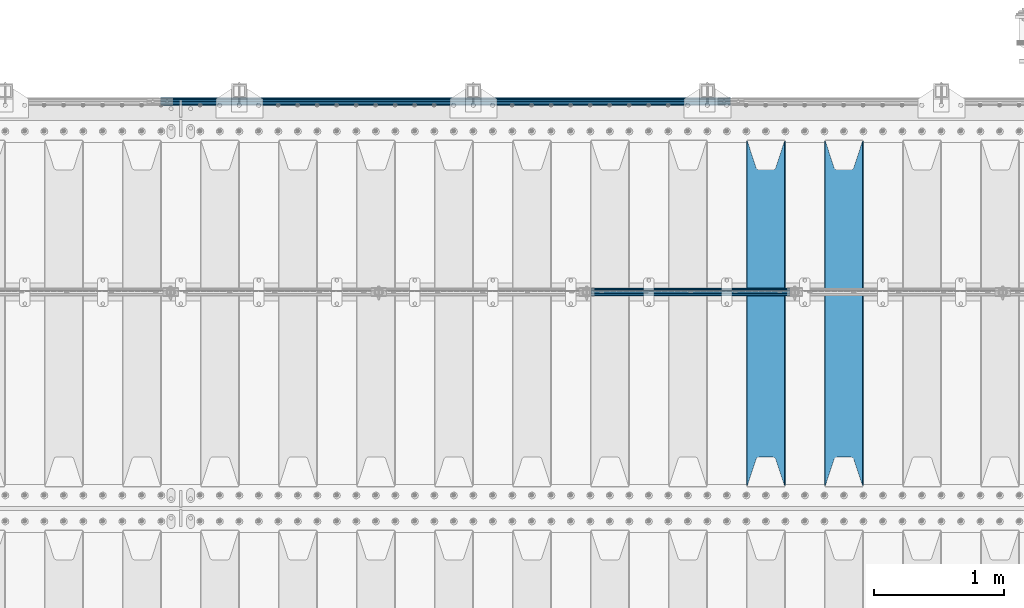
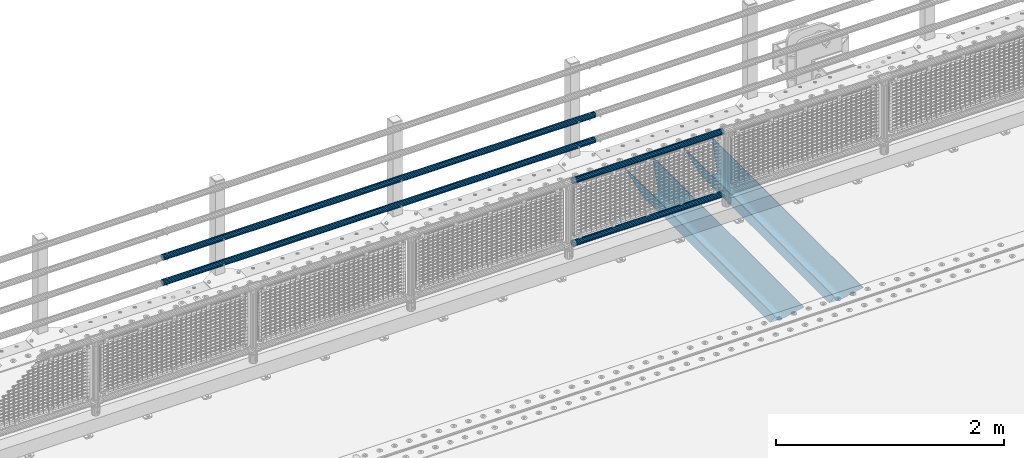
# One storey, part 104 of 208: 6 beams.
"""IFC2X3 building model written with IfcOpenShell, lengths in millimetres."""

from ifc_helpers import new_model, si_unit, frame, origin_with_axes, place, context, subcontext, project, spatial, faceted_brep, material, type_object, element, save


model = new_model("IFC2X3")

# Units and contexts
model_context = context("Model", 3, precision=1e-05, world=origin_with_axes())
body_context = subcontext(model_context, "Body", "Model", "MODEL_VIEW")
ifc_project = project(units=[si_unit("LENGTHUNIT", "METRE", prefix="MILLI"), si_unit("AREAUNIT", "SQUARE_METRE"), si_unit("VOLUMEUNIT", "CUBIC_METRE"), si_unit("MASSUNIT", "GRAM", prefix="KILO"), si_unit("TIMEUNIT", "SECOND"), si_unit("PLANEANGLEUNIT", "RADIAN"), si_unit("SOLIDANGLEUNIT", "STERADIAN"), si_unit("THERMODYNAMICTEMPERATUREUNIT", "DEGREE_CELSIUS"), si_unit("LUMINOUSINTENSITYUNIT", "LUMEN")], contexts=[model_context])

# Site, building, storey
site_placement = place(None, origin_with_axes())
site = spatial("IfcSite", under=ifc_project, at=site_placement, CompositionType="ELEMENT")
building_placement = place(site_placement, origin_with_axes())
building = spatial("IfcBuilding", under=site, at=building_placement, Name="Standard", CompositionType="ELEMENT")
storey_placement = place(building_placement, origin_with_axes())
storey = spatial("IfcBuildingStorey", under=building, at=storey_placement, Name="Undefined", CompositionType="ELEMENT", Elevation=0.0)

# Beams
ifc_material_1 = material(Name="STEEL/S355N")
beam_type_1 = type_object("IfcBeamType", PredefinedType="NOTDEFINED")
beam_1_placement = place(storey_placement, frame((-31850.0, 3175.0, -115.0), z_axis=(0.0, 0.0, 1.0), x_axis=(0.0, 1.0, 0.0)))
element("IfcBeam", 1, at=beam_1_placement, inside=storey, type_object=beam_type_1, material=ifc_material_1, context=body_context, shape_type="Brep", body=[
    faceted_brep([(0.0, 150.0, 115.0), (0.0, 143.689999999999, 115.0), (2650.00000000297, 143.689999999999, 115.0), (2650.00000000297, 150.0, 115.0), (2650.00000000297, 142.059565218402, 110.0000000031), (2650.00000000297, 148.369565218403, 110.0000000031), (2441.90079219208, -80.1103600731112, -98.0992078077845), (2437.7588105432, -77.5672621345584, -102.241189456673), (2434.06523489746, -74.4080125315522, -105.934765102404), (2430.91086095089, -70.710272125576, -109.089139048974), (2428.37322971128, -66.5649389910068, -111.626770288588), (2426.51472138055, -62.0739139532889, -113.485278619323), (2425.38102192091, -57.3475956567672, -114.618978078955), (2424.99999999987, -52.5021667386536, -115.0), (2424.99999999987, 52.5021667386536, -115.0), (2425.38102192091, 57.3475956567672, -114.618978078955), (2426.51472138055, 62.0739139532889, -113.485278619323), (2428.37322971128, 66.5649389910068, -111.626770288588), (2430.91086095089, 70.710272125576, -109.089139048974), (2434.06523489746, 74.4080125315522, -105.934765102404), (2437.7588105432, 77.5672621345584, -102.241189456673), (2441.90079219208, 80.1103600731112, -98.0992078077846), (2446.38936140511, 81.9747917625791, -93.6106385947584), (2448.24948500409, 76.2713538057251, -91.7505149957729), (2444.62967112262, 74.76777986261, -95.3703288772456), (2441.28936334126, 72.7168944282894, -98.710636658607), (2438.31067330438, 70.1691124903846, -101.689326695487), (2435.76682334747, 67.1870637758839, -104.233176652398), (2433.72034654133, 63.8440531834895, -106.279653458539), (2432.22154950041, 60.222258798236, -107.778450499454), (2431.30727574265, 56.4107117849089, -108.692724257221), (2430.99999999987, 52.5031078186876, -109.0), (2430.99999999987, -52.5031078186876, -109.0), (2431.30727574265, -56.4107117849089, -108.692724257221), (2432.22154950041, -60.222258798236, -107.778450499454), (2433.72034654133, -63.8440531834895, -106.279653458539), (2435.76682334747, -67.1870637758839, -104.233176652398), (2438.31067330438, -70.1691124903846, -101.689326695487), (2441.28936334126, -72.7168944282894, -98.7106366586071), (2444.62967112262, -74.76777986261, -95.3703288772457), (2448.24948500409, -76.2713538057251, -91.7505149957729), (2650.00000000297, -142.059565218402, 110.0000000031), (2650.00000000297, -148.369565218403, 110.0000000031), (2446.38936140511, -81.9747917625791, -93.6106385947584), (2650.00000000297, -143.689999999999, 115.0), (2650.00000000297, -150.0, 115.0), (0.0, -143.689999999999, 115.0), (0.0, -150.0, 115.0), (0.0, -148.369565218261, 110.000000002663), (203.610638597421, -81.9747917625791, -93.6106385947584), (208.099207810448, -80.1103600731112, -98.0992078077845), (212.241189459336, -77.5672621345584, -102.241189456673), (215.934765105067, -74.4080125315522, -105.934765102404), (219.089139051637, -70.710272125576, -109.089139048974), (221.626770291251, -66.5649389910068, -111.626770288588), (223.485278621986, -62.0739139532889, -113.485278619323), (224.618978081618, -57.3475956567672, -114.618978078955), (225.000000002663, -52.5021667386536, -115.0), (225.000000002663, 52.5021667386536, -115.0), (224.618978081618, 57.3475956567672, -114.618978078955), (223.485278621986, 62.0739139532889, -113.485278619323), (221.626770291251, 66.5649389910068, -111.626770288588), (219.089139051637, 70.710272125576, -109.089139048974), (215.934765105067, 74.4080125315522, -105.934765102404), (212.241189459336, 77.5672621345584, -102.241189456673), (208.099207810448, 80.1103600731112, -98.0992078077846), (203.610638597421, 81.9747917625791, -93.6106385947584), (0.0, 148.369565218261, 110.000000002663), (0.0, 142.05956521826, 110.000000002663), (201.750514998436, 76.2713538057251, -91.7505149957729), (205.370328879908, 74.76777986261, -95.3703288772456), (208.71063666127, 72.7168944282894, -98.710636658607), (211.68932669815, 70.1691124903846, -101.689326695487), (214.233176655061, 67.1870637758839, -104.233176652398), (216.279653461202, 63.8440531834895, -106.279653458539), (217.778450502116, 60.222258798236, -107.778450499454), (218.692724259884, 56.4107117849089, -108.692724257221), (219.000000002663, 52.5031078186876, -109.0), (219.000000002663, -52.5031078186876, -109.0), (218.692724259884, -56.4107117849089, -108.692724257221), (217.778450502116, -60.222258798236, -107.778450499454), (216.279653461202, -63.8440531834895, -106.279653458539), (214.233176655061, -67.1870637758839, -104.233176652398), (211.68932669815, -70.1691124903846, -101.689326695487), (208.71063666127, -72.7168944282894, -98.7106366586071), (205.370328879908, -74.76777986261, -95.3703288772457), (201.750514998436, -76.2713538057251, -91.7505149957729), (0.0, -142.05956521826, 110.000000002663)], [[[0, 1, 2, 3]], [[3, 2, 4, 5]], [[6, 7, 8, 9, 10, 11, 12, 13, 14, 15, 16, 17, 18, 19, 20, 21, 22, 5, 4, 23, 24, 25, 26, 27, 28, 29, 30, 31, 32, 33, 34, 35, 36, 37, 38, 39, 40, 41, 42, 43]], [[44, 45, 42, 41]], [[46, 47, 45, 44]], [[43, 42, 45, 47, 48, 49]], [[6, 43, 49, 50]], [[7, 6, 50, 51]], [[8, 7, 51, 52]], [[9, 8, 52, 53]], [[10, 9, 53, 54]], [[11, 10, 54, 55]], [[12, 11, 55, 56]], [[13, 12, 56, 57]], [[14, 13, 57, 58]], [[15, 14, 58, 59]], [[16, 15, 59, 60]], [[17, 16, 60, 61]], [[18, 17, 61, 62]], [[19, 18, 62, 63]], [[20, 19, 63, 64]], [[21, 20, 64, 65]], [[22, 21, 65, 66]], [[0, 3, 5, 22, 66, 67]], [[1, 0, 67, 68]], [[23, 4, 2, 1, 68, 69]], [[24, 23, 69, 70]], [[25, 24, 70, 71]], [[26, 25, 71, 72]], [[27, 26, 72, 73]], [[28, 27, 73, 74]], [[29, 28, 74, 75]], [[30, 29, 75, 76]], [[31, 30, 76, 77]], [[32, 31, 77, 78]], [[33, 32, 78, 79]], [[34, 33, 79, 80]], [[35, 34, 80, 81]], [[36, 35, 81, 82]], [[37, 36, 82, 83]], [[38, 37, 83, 84]], [[39, 38, 84, 85]], [[40, 39, 85, 86]], [[46, 44, 41, 40, 86, 87]], [[47, 46, 87, 48]], [[86, 85, 84, 83, 82, 81, 80, 79, 78, 77, 76, 75, 74, 73, 72, 71, 70, 69, 68, 67, 66, 65, 64, 63, 62, 61, 60, 59, 58, 57, 56, 55, 54, 53, 52, 51, 50, 49, 48, 87]]]),
])
beam_2_placement = place(storey_placement, frame((-32450.0, 3175.0, -115.0), z_axis=(0.0, 0.0, 1.0), x_axis=(0.0, 1.0, 0.0)))
element("IfcBeam", 2, at=beam_2_placement, inside=storey, type_object=beam_type_1, material=ifc_material_1, context=body_context, shape_type="Brep", body=[
    faceted_brep([(0.0, 150.0, 115.0), (0.0, 143.689999999999, 115.0), (2650.00000000297, 143.689999999999, 115.0), (2650.00000000297, 150.0, 115.0), (2650.00000000297, 142.059565218402, 110.0000000031), (2650.00000000297, 148.369565218403, 110.0000000031), (2441.90079219208, -80.1103600731112, -98.0992078077845), (2437.7588105432, -77.5672621345584, -102.241189456673), (2434.06523489746, -74.4080125315522, -105.934765102404), (2430.91086095089, -70.710272125576, -109.089139048974), (2428.37322971128, -66.5649389910068, -111.626770288588), (2426.51472138055, -62.0739139532889, -113.485278619323), (2425.38102192091, -57.3475956567672, -114.618978078955), (2424.99999999987, -52.5021667386536, -115.0), (2424.99999999987, 52.5021667386536, -115.0), (2425.38102192091, 57.3475956567672, -114.618978078955), (2426.51472138055, 62.0739139532889, -113.485278619323), (2428.37322971128, 66.5649389910068, -111.626770288588), (2430.91086095089, 70.710272125576, -109.089139048974), (2434.06523489746, 74.4080125315522, -105.934765102404), (2437.7588105432, 77.5672621345584, -102.241189456673), (2441.90079219208, 80.1103600731112, -98.0992078077846), (2446.38936140511, 81.9747917625791, -93.6106385947584), (2448.24948500409, 76.2713538057251, -91.7505149957729), (2444.62967112262, 74.76777986261, -95.3703288772456), (2441.28936334126, 72.7168944282894, -98.710636658607), (2438.31067330438, 70.1691124903846, -101.689326695487), (2435.76682334747, 67.1870637758839, -104.233176652398), (2433.72034654133, 63.8440531834895, -106.279653458539), (2432.22154950041, 60.222258798236, -107.778450499454), (2431.30727574265, 56.4107117849089, -108.692724257221), (2430.99999999987, 52.5031078186876, -109.0), (2430.99999999987, -52.5031078186876, -109.0), (2431.30727574265, -56.4107117849089, -108.692724257221), (2432.22154950041, -60.222258798236, -107.778450499454), (2433.72034654133, -63.8440531834895, -106.279653458539), (2435.76682334747, -67.1870637758839, -104.233176652398), (2438.31067330438, -70.1691124903846, -101.689326695487), (2441.28936334126, -72.7168944282894, -98.7106366586071), (2444.62967112262, -74.76777986261, -95.3703288772457), (2448.24948500409, -76.2713538057251, -91.7505149957729), (2650.00000000297, -142.059565218402, 110.0000000031), (2650.00000000297, -148.369565218403, 110.0000000031), (2446.38936140511, -81.9747917625791, -93.6106385947584), (2650.00000000297, -143.689999999999, 115.0), (2650.00000000297, -150.0, 115.0), (0.0, -143.689999999999, 115.0), (0.0, -150.0, 115.0), (0.0, -148.369565218261, 110.000000002663), (203.610638597421, -81.9747917625791, -93.6106385947584), (208.099207810448, -80.1103600731112, -98.0992078077845), (212.241189459336, -77.5672621345584, -102.241189456673), (215.934765105067, -74.4080125315522, -105.934765102404), (219.089139051637, -70.710272125576, -109.089139048974), (221.626770291251, -66.5649389910068, -111.626770288588), (223.485278621986, -62.0739139532889, -113.485278619323), (224.618978081618, -57.3475956567672, -114.618978078955), (225.000000002663, -52.5021667386536, -115.0), (225.000000002663, 52.5021667386536, -115.0), (224.618978081618, 57.3475956567672, -114.618978078955), (223.485278621986, 62.0739139532889, -113.485278619323), (221.626770291251, 66.5649389910068, -111.626770288588), (219.089139051637, 70.710272125576, -109.089139048974), (215.934765105067, 74.4080125315522, -105.934765102404), (212.241189459336, 77.5672621345584, -102.241189456673), (208.099207810448, 80.1103600731112, -98.0992078077846), (203.610638597421, 81.9747917625791, -93.6106385947584), (0.0, 148.369565218261, 110.000000002663), (0.0, 142.05956521826, 110.000000002663), (201.750514998436, 76.2713538057251, -91.7505149957729), (205.370328879908, 74.76777986261, -95.3703288772456), (208.71063666127, 72.7168944282894, -98.710636658607), (211.68932669815, 70.1691124903846, -101.689326695487), (214.233176655061, 67.1870637758839, -104.233176652398), (216.279653461202, 63.8440531834895, -106.279653458539), (217.778450502116, 60.222258798236, -107.778450499454), (218.692724259884, 56.4107117849089, -108.692724257221), (219.000000002663, 52.5031078186876, -109.0), (219.000000002663, -52.5031078186876, -109.0), (218.692724259884, -56.4107117849089, -108.692724257221), (217.778450502116, -60.222258798236, -107.778450499454), (216.279653461202, -63.8440531834895, -106.279653458539), (214.233176655061, -67.1870637758839, -104.233176652398), (211.68932669815, -70.1691124903846, -101.689326695487), (208.71063666127, -72.7168944282894, -98.7106366586071), (205.370328879908, -74.76777986261, -95.3703288772457), (201.750514998436, -76.2713538057251, -91.7505149957729), (0.0, -142.05956521826, 110.000000002663)], [[[0, 1, 2, 3]], [[3, 2, 4, 5]], [[6, 7, 8, 9, 10, 11, 12, 13, 14, 15, 16, 17, 18, 19, 20, 21, 22, 5, 4, 23, 24, 25, 26, 27, 28, 29, 30, 31, 32, 33, 34, 35, 36, 37, 38, 39, 40, 41, 42, 43]], [[44, 45, 42, 41]], [[46, 47, 45, 44]], [[43, 42, 45, 47, 48, 49]], [[6, 43, 49, 50]], [[7, 6, 50, 51]], [[8, 7, 51, 52]], [[9, 8, 52, 53]], [[10, 9, 53, 54]], [[11, 10, 54, 55]], [[12, 11, 55, 56]], [[13, 12, 56, 57]], [[14, 13, 57, 58]], [[15, 14, 58, 59]], [[16, 15, 59, 60]], [[17, 16, 60, 61]], [[18, 17, 61, 62]], [[19, 18, 62, 63]], [[20, 19, 63, 64]], [[21, 20, 64, 65]], [[22, 21, 65, 66]], [[0, 3, 5, 22, 66, 67]], [[1, 0, 67, 68]], [[23, 4, 2, 1, 68, 69]], [[24, 23, 69, 70]], [[25, 24, 70, 71]], [[26, 25, 71, 72]], [[27, 26, 72, 73]], [[28, 27, 73, 74]], [[29, 28, 74, 75]], [[30, 29, 75, 76]], [[31, 30, 76, 77]], [[32, 31, 77, 78]], [[33, 32, 78, 79]], [[34, 33, 79, 80]], [[35, 34, 80, 81]], [[36, 35, 81, 82]], [[37, 36, 82, 83]], [[38, 37, 83, 84]], [[39, 38, 84, 85]], [[40, 39, 85, 86]], [[46, 44, 41, 40, 86, 87]], [[47, 46, 87, 48]], [[86, 85, 84, 83, 82, 81, 80, 79, 78, 77, 76, 75, 74, 73, 72, 71, 70, 69, 68, 67, 66, 65, 64, 63, 62, 61, 60, 59, 58, 57, 56, 55, 54, 53, 52, 51, 50, 49, 48, 87]]]),
])
ifc_material_2 = material()
beam_type_2 = type_object("IfcBeamType", PredefinedType="NOTDEFINED")
beam_3_placement = place(storey_placement, frame((-33794.15, 4664.5, 298.170000000004), z_axis=(0.0, 0.0, 1.0), x_axis=(1.0, 0.0, 0.0)))
element("IfcBeam", 3, at=beam_3_placement, inside=storey, type_object=beam_type_2, material=ifc_material_2, context=body_context, shape_type="Brep", body=[
    faceted_brep([(0.0, -25.3500000000004, 0.0), (0.0, -23.4203461491616, 9.70102501045403), (1530.0, -23.4203461491616, 9.70102501045506), (1530.0, -25.3500000000004, 0.0), (0.0, -17.9251569030794, 17.9251569030785), (1530.0, -17.9251569030794, 17.925156903079), (0.0, -9.70102501045494, 23.4203461491597), (1530.0, -9.70102501045494, 23.4203461491611), (0.0, 0.0, 25.3499999999985), (1530.0, 0.0, 25.35), (0.0, 9.70102501045494, 23.4203461491597), (1530.0, 9.70102501045494, 23.4203461491611), (0.0, 17.9251569030794, 17.9251569030785), (1530.0, 17.9251569030794, 17.925156903079), (0.0, 23.4203461491616, 9.70102501045403), (1530.0, 23.4203461491616, 9.701025010455), (0.0, 25.3500000000004, 0.0), (1530.0, 25.3500000000004, 0.0), (0.0, 23.4203461491616, -9.70102501045403), (1530.0, 23.4203461491616, -9.70102501045506), (0.0, 17.9251569030794, -17.9251569030785), (1530.0, 17.9251569030794, -17.925156903079), (0.0, 9.70102501045494, -23.4203461491597), (1530.0, 9.70102501045494, -23.4203461491611), (0.0, 0.0, -25.3499999999985), (1530.0, 0.0, -25.35), (0.0, -9.70102501045494, -23.4203461491597), (1530.0, -9.70102501045494, -23.4203461491611), (0.0, -17.9251569030794, -17.9251569030785), (1530.0, -17.9251569030794, -17.925156903079), (0.0, -23.4203461491616, -9.70102501045403), (1530.0, -23.4203461491616, -9.701025010455), (0.0, -30.1499999999996, 0.0), (0.0, -27.8549679052148, -11.5379054858058), (1530.0, -27.8549679052148, -11.5379054858075), (1530.0, -30.1499999999996, 0.0), (0.0, -21.3192694527743, -21.3192694527752), (1530.0, -21.3192694527743, -21.3192694527744), (0.0, -11.5379054858076, -27.8549679052157), (1530.0, -11.5379054858076, -27.8549679052153), (0.0, 0.0, -30.1500000000015), (1530.0, 0.0, -30.15), (0.0, 11.5379054858076, -27.8549679052157), (1530.0, 11.5379054858076, -27.8549679052153), (0.0, 21.3192694527743, -21.3192694527752), (1530.0, 21.3192694527743, -21.3192694527744), (0.0, 27.8549679052157, -11.5379054858058), (1530.0, 27.8549679052157, -11.5379054858075), (0.0, 30.1499999999996, 0.0), (1530.0, 30.1499999999996, 0.0), (0.0, 27.8549679052157, 11.5379054858058), (1530.0, 27.8549679052157, 11.5379054858075), (0.0, 21.3192694527743, 21.3192694527752), (1530.0, 21.3192694527743, 21.3192694527744), (0.0, 11.5379054858076, 27.8549679052157), (1530.0, 11.5379054858076, 27.8549679052153), (0.0, 0.0, 30.1500000000015), (1530.0, 0.0, 30.15), (0.0, -11.5379054858076, 27.8549679052157), (1530.0, -11.5379054858076, 27.8549679052153), (0.0, -21.3192694527743, 21.3192694527752), (1530.0, -21.3192694527743, 21.3192694527744), (0.0, -27.8549679052157, 11.5379054858058), (1530.0, -27.8549679052157, 11.5379054858075)], [[[0, 1, 2, 3]], [[1, 4, 5, 2]], [[4, 6, 7, 5]], [[6, 8, 9, 7]], [[8, 10, 11, 9]], [[10, 12, 13, 11]], [[12, 14, 15, 13]], [[14, 16, 17, 15]], [[16, 18, 19, 17]], [[18, 20, 21, 19]], [[20, 22, 23, 21]], [[22, 24, 25, 23]], [[24, 26, 27, 25]], [[26, 28, 29, 27]], [[28, 30, 31, 29]], [[30, 0, 3, 31]], [[32, 33, 34, 35]], [[33, 36, 37, 34]], [[36, 38, 39, 37]], [[38, 40, 41, 39]], [[40, 42, 43, 41]], [[42, 44, 45, 43]], [[44, 46, 47, 45]], [[46, 48, 49, 47]], [[48, 50, 51, 49]], [[50, 52, 53, 51]], [[52, 54, 55, 53]], [[54, 56, 57, 55]], [[56, 58, 59, 57]], [[58, 60, 61, 59]], [[60, 62, 63, 61]], [[62, 32, 35, 63]], [[37, 39, 41, 43, 45, 47, 49, 51, 53, 55, 57, 59, 61, 63, 35, 34], [5, 7, 9, 11, 13, 15, 17, 19, 21, 23, 25, 27, 29, 31, 3, 2]], [[62, 60, 58, 56, 54, 52, 50, 48, 46, 44, 42, 40, 38, 36, 33, 32], [30, 28, 26, 24, 22, 20, 18, 16, 14, 12, 10, 8, 6, 4, 1, 0]]]),
])
beam_4_placement = place(storey_placement, frame((-33794.15, 4664.5, 969.850000000003), z_axis=(0.0, 0.0, 1.0), x_axis=(1.0, 0.0, 0.0)))
element("IfcBeam", 4, at=beam_4_placement, inside=storey, type_object=beam_type_2, material=ifc_material_2, context=body_context, shape_type="Brep", body=[
    faceted_brep([(0.0, -25.3500000000004, 0.0), (0.0, -23.4203461491616, 9.70102501045403), (1530.0, -23.4203461491616, 9.70102501045506), (1530.0, -25.3500000000004, 0.0), (0.0, -17.9251569030794, 17.9251569030785), (1530.0, -17.9251569030794, 17.925156903079), (0.0, -9.70102501045494, 23.4203461491597), (1530.0, -9.70102501045494, 23.4203461491611), (0.0, 0.0, 25.3499999999985), (1530.0, 0.0, 25.35), (0.0, 9.70102501045494, 23.4203461491597), (1530.0, 9.70102501045494, 23.4203461491611), (0.0, 17.9251569030794, 17.9251569030785), (1530.0, 17.9251569030794, 17.925156903079), (0.0, 23.4203461491616, 9.70102501045403), (1530.0, 23.4203461491616, 9.701025010455), (0.0, 25.3500000000004, 0.0), (1530.0, 25.3500000000004, 0.0), (0.0, 23.4203461491616, -9.70102501045403), (1530.0, 23.4203461491616, -9.70102501045506), (0.0, 17.9251569030794, -17.9251569030785), (1530.0, 17.9251569030794, -17.925156903079), (0.0, 9.70102501045494, -23.4203461491597), (1530.0, 9.70102501045494, -23.4203461491611), (0.0, 0.0, -25.3499999999985), (1530.0, 0.0, -25.35), (0.0, -9.70102501045494, -23.4203461491597), (1530.0, -9.70102501045494, -23.4203461491611), (0.0, -17.9251569030794, -17.9251569030785), (1530.0, -17.9251569030794, -17.925156903079), (0.0, -23.4203461491616, -9.70102501045403), (1530.0, -23.4203461491616, -9.701025010455), (0.0, -30.1499999999996, 0.0), (0.0, -27.8549679052148, -11.5379054858058), (1530.0, -27.8549679052148, -11.5379054858075), (1530.0, -30.1499999999996, 0.0), (0.0, -21.3192694527743, -21.3192694527752), (1530.0, -21.3192694527743, -21.3192694527744), (0.0, -11.5379054858076, -27.8549679052157), (1530.0, -11.5379054858076, -27.8549679052153), (0.0, 0.0, -30.1500000000015), (1530.0, 0.0, -30.15), (0.0, 11.5379054858076, -27.8549679052157), (1530.0, 11.5379054858076, -27.8549679052153), (0.0, 21.3192694527743, -21.3192694527752), (1530.0, 21.3192694527743, -21.3192694527744), (0.0, 27.8549679052157, -11.5379054858058), (1530.0, 27.8549679052157, -11.5379054858075), (0.0, 30.1499999999996, 0.0), (1530.0, 30.1499999999996, 0.0), (0.0, 27.8549679052157, 11.5379054858058), (1530.0, 27.8549679052157, 11.5379054858075), (0.0, 21.3192694527743, 21.3192694527752), (1530.0, 21.3192694527743, 21.3192694527744), (0.0, 11.5379054858076, 27.8549679052157), (1530.0, 11.5379054858076, 27.8549679052153), (0.0, 0.0, 30.1500000000015), (1530.0, 0.0, 30.15), (0.0, -11.5379054858076, 27.8549679052157), (1530.0, -11.5379054858076, 27.8549679052153), (0.0, -21.3192694527743, 21.3192694527752), (1530.0, -21.3192694527743, 21.3192694527744), (0.0, -27.8549679052157, 11.5379054858058), (1530.0, -27.8549679052157, 11.5379054858075)], [[[0, 1, 2, 3]], [[1, 4, 5, 2]], [[4, 6, 7, 5]], [[6, 8, 9, 7]], [[8, 10, 11, 9]], [[10, 12, 13, 11]], [[12, 14, 15, 13]], [[14, 16, 17, 15]], [[16, 18, 19, 17]], [[18, 20, 21, 19]], [[20, 22, 23, 21]], [[22, 24, 25, 23]], [[24, 26, 27, 25]], [[26, 28, 29, 27]], [[28, 30, 31, 29]], [[30, 0, 3, 31]], [[32, 33, 34, 35]], [[33, 36, 37, 34]], [[36, 38, 39, 37]], [[38, 40, 41, 39]], [[40, 42, 43, 41]], [[42, 44, 45, 43]], [[44, 46, 47, 45]], [[46, 48, 49, 47]], [[48, 50, 51, 49]], [[50, 52, 53, 51]], [[52, 54, 55, 53]], [[54, 56, 57, 55]], [[56, 58, 59, 57]], [[58, 60, 61, 59]], [[60, 62, 63, 61]], [[62, 32, 35, 63]], [[37, 39, 41, 43, 45, 47, 49, 51, 53, 55, 57, 59, 61, 63, 35, 34], [5, 7, 9, 11, 13, 15, 17, 19, 21, 23, 25, 27, 29, 31, 3, 2]], [[62, 60, 58, 56, 54, 52, 50, 48, 46, 44, 42, 40, 38, 36, 33, 32], [30, 28, 26, 24, 22, 20, 18, 16, 14, 12, 10, 8, 6, 4, 1, 0]]]),
])
beam_type_3 = type_object("IfcBeamType", PredefinedType="NOTDEFINED")
beam_5_placement = place(storey_placement, frame((-32722.0000000001, 6129.85000000009, 149.849999999725), z_axis=(0.0, 0.0, -1.0), x_axis=(-1.0, 0.0, 0.0)))
element("IfcBeam", 5, at=beam_5_placement, inside=storey, type_object=beam_type_3, material=ifc_material_2, context=body_context, shape_type="Brep", body=[
    faceted_brep([(0.0, -26.5500000000002, 0.0), (0.0, -24.5290015881747, 10.1602451292931), (4384.00249699992, -24.5290015881747, 10.1602451292931), (4384.00249699992, -26.5500000000002, 0.0), (0.0, -18.7736850405026, 18.7736850405028), (4384.00249699992, -18.7736850405026, 18.7736850405028), (0.0, -10.1602451292929, 24.5290015881747), (4384.00249699992, -10.1602451292929, 24.5290015881747), (0.0, 0.0, 26.55), (4384.00249699992, 0.0, 26.55), (0.0, 10.1602451292929, 24.5290015881747), (4384.00249699992, 10.1602451292929, 24.5290015881747), (0.0, 18.7736850405026, 18.7736850405028), (4384.00249699992, 18.7736850405026, 18.7736850405028), (0.0, 24.5290015881747, 10.1602451292931), (4384.00249699992, 24.5290015881747, 10.1602451292931), (0.0, 26.5500000000002, 0.0), (4384.00249699992, 26.5500000000002, 0.0), (0.0, 24.5290015881747, -10.1602451292931), (4384.00249699992, 24.5290015881747, -10.1602451292931), (0.0, 18.7736850405026, -18.7736850405028), (4384.00249699992, 18.7736850405026, -18.7736850405028), (0.0, 10.1602451292929, -24.5290015881747), (4384.00249699992, 10.1602451292929, -24.5290015881747), (0.0, 0.0, -26.55), (4384.00249699992, 0.0, -26.55), (0.0, -10.1602451292929, -24.5290015881747), (4384.00249699992, -10.1602451292929, -24.5290015881747), (0.0, -18.7736850405026, -18.7736850405028), (4384.00249699992, -18.7736850405026, -18.7736850405028), (0.0, -24.5290015881747, -10.1602451292931), (4384.00249699992, -24.5290015881747, -10.1602451292931), (0.0, -30.1499999999996, 0.0), (0.0, -27.8549679052148, -11.5379054858058), (4384.00249699992, -27.8549679052148, -11.5379054858075), (4384.00249699992, -30.1499999999996, 0.0), (0.0, -21.3192694527743, -21.3192694527752), (4384.00249699992, -21.3192694527743, -21.3192694527744), (0.0, -11.5379054858076, -27.8549679052157), (4384.00249699992, -11.5379054858076, -27.8549679052153), (0.0, 0.0, -30.1500000000015), (4384.00249699992, 0.0, -30.15), (0.0, 11.5379054858076, -27.8549679052157), (4384.00249699992, 11.5379054858076, -27.8549679052153), (0.0, 21.3192694527743, -21.3192694527752), (4384.00249699992, 21.3192694527743, -21.3192694527744), (0.0, 27.8549679052157, -11.5379054858058), (4384.00249699992, 27.8549679052157, -11.5379054858074), (0.0, 30.1499999999996, 0.0), (4384.00249699992, 30.1499999999996, 0.0), (0.0, 27.8549679052157, 11.5379054858058), (4384.00249699992, 27.8549679052157, 11.5379054858075), (0.0, 21.3192694527743, 21.3192694527752), (4384.00249699992, 21.3192694527743, 21.3192694527744), (0.0, 11.5379054858076, 27.8549679052157), (4384.00249699992, 11.5379054858076, 27.8549679052153), (0.0, 0.0, 30.1500000000015), (4384.00249699992, 0.0, 30.15), (0.0, -11.5379054858076, 27.8549679052157), (4384.00249699992, -11.5379054858076, 27.8549679052153), (0.0, -21.3192694527743, 21.3192694527752), (4384.00249699992, -21.3192694527743, 21.3192694527744), (0.0, -27.8549679052157, 11.5379054858058), (4384.00249699992, -27.8549679052157, 11.5379054858075)], [[[0, 1, 2, 3]], [[1, 4, 5, 2]], [[4, 6, 7, 5]], [[6, 8, 9, 7]], [[8, 10, 11, 9]], [[10, 12, 13, 11]], [[12, 14, 15, 13]], [[14, 16, 17, 15]], [[16, 18, 19, 17]], [[18, 20, 21, 19]], [[20, 22, 23, 21]], [[22, 24, 25, 23]], [[24, 26, 27, 25]], [[26, 28, 29, 27]], [[28, 30, 31, 29]], [[30, 0, 3, 31]], [[32, 33, 34, 35]], [[33, 36, 37, 34]], [[36, 38, 39, 37]], [[38, 40, 41, 39]], [[40, 42, 43, 41]], [[42, 44, 45, 43]], [[44, 46, 47, 45]], [[46, 48, 49, 47]], [[48, 50, 51, 49]], [[50, 52, 53, 51]], [[52, 54, 55, 53]], [[54, 56, 57, 55]], [[56, 58, 59, 57]], [[58, 60, 61, 59]], [[60, 62, 63, 61]], [[62, 32, 35, 63]], [[37, 39, 41, 43, 45, 47, 49, 51, 53, 55, 57, 59, 61, 63, 35, 34], [5, 7, 9, 11, 13, 15, 17, 19, 21, 23, 25, 27, 29, 31, 3, 2]], [[62, 60, 58, 56, 54, 52, 50, 48, 46, 44, 42, 40, 38, 36, 33, 32], [30, 28, 26, 24, 22, 20, 18, 16, 14, 12, 10, 8, 6, 4, 1, 0]]]),
])
beam_6_placement = place(storey_placement, frame((-32722.0000000001, 6129.85000000009, 420.149999999728), z_axis=(0.0, 0.0, -1.0), x_axis=(-1.0, 0.0, 0.0)))
element("IfcBeam", 6, at=beam_6_placement, inside=storey, type_object=beam_type_3, material=ifc_material_2, context=body_context, shape_type="Brep", body=[
    faceted_brep([(0.0, -26.5500000000002, 0.0), (0.0, -24.5290015881747, 10.1602451292931), (4384.00249699992, -24.5290015881747, 10.1602451292931), (4384.00249699992, -26.5500000000002, 0.0), (0.0, -18.7736850405026, 18.7736850405028), (4384.00249699992, -18.7736850405026, 18.7736850405028), (0.0, -10.1602451292929, 24.5290015881747), (4384.00249699992, -10.1602451292929, 24.5290015881747), (0.0, 0.0, 26.55), (4384.00249699992, 0.0, 26.55), (0.0, 10.1602451292929, 24.5290015881747), (4384.00249699992, 10.1602451292929, 24.5290015881747), (0.0, 18.7736850405026, 18.7736850405028), (4384.00249699992, 18.7736850405026, 18.7736850405028), (0.0, 24.5290015881747, 10.1602451292931), (4384.00249699992, 24.5290015881747, 10.1602451292931), (0.0, 26.5500000000002, 0.0), (4384.00249699992, 26.5500000000002, 0.0), (0.0, 24.5290015881747, -10.1602451292931), (4384.00249699992, 24.5290015881747, -10.1602451292931), (0.0, 18.7736850405026, -18.7736850405028), (4384.00249699992, 18.7736850405026, -18.7736850405028), (0.0, 10.1602451292929, -24.5290015881747), (4384.00249699992, 10.1602451292929, -24.5290015881747), (0.0, 0.0, -26.55), (4384.00249699992, 0.0, -26.55), (0.0, -10.1602451292929, -24.5290015881747), (4384.00249699992, -10.1602451292929, -24.5290015881747), (0.0, -18.7736850405026, -18.7736850405028), (4384.00249699992, -18.7736850405026, -18.7736850405028), (0.0, -24.5290015881747, -10.1602451292931), (4384.00249699992, -24.5290015881747, -10.1602451292931), (0.0, -30.1499999999996, 0.0), (0.0, -27.8549679052148, -11.5379054858058), (4384.00249699992, -27.8549679052148, -11.5379054858075), (4384.00249699992, -30.1499999999996, 0.0), (0.0, -21.3192694527743, -21.3192694527752), (4384.00249699992, -21.3192694527743, -21.3192694527744), (0.0, -11.5379054858076, -27.8549679052157), (4384.00249699992, -11.5379054858076, -27.8549679052153), (0.0, 0.0, -30.1500000000015), (4384.00249699992, 0.0, -30.15), (0.0, 11.5379054858076, -27.8549679052157), (4384.00249699992, 11.5379054858076, -27.8549679052153), (0.0, 21.3192694527743, -21.3192694527752), (4384.00249699992, 21.3192694527743, -21.3192694527744), (0.0, 27.8549679052157, -11.5379054858058), (4384.00249699992, 27.8549679052157, -11.5379054858074), (0.0, 30.1499999999996, 0.0), (4384.00249699992, 30.1499999999996, 0.0), (0.0, 27.8549679052157, 11.5379054858058), (4384.00249699992, 27.8549679052157, 11.5379054858075), (0.0, 21.3192694527743, 21.3192694527752), (4384.00249699992, 21.3192694527743, 21.3192694527744), (0.0, 11.5379054858076, 27.8549679052157), (4384.00249699992, 11.5379054858076, 27.8549679052153), (0.0, 0.0, 30.1500000000015), (4384.00249699992, 0.0, 30.15), (0.0, -11.5379054858076, 27.8549679052157), (4384.00249699992, -11.5379054858076, 27.8549679052153), (0.0, -21.3192694527743, 21.3192694527752), (4384.00249699992, -21.3192694527743, 21.3192694527744), (0.0, -27.8549679052157, 11.5379054858058), (4384.00249699992, -27.8549679052157, 11.5379054858075)], [[[0, 1, 2, 3]], [[1, 4, 5, 2]], [[4, 6, 7, 5]], [[6, 8, 9, 7]], [[8, 10, 11, 9]], [[10, 12, 13, 11]], [[12, 14, 15, 13]], [[14, 16, 17, 15]], [[16, 18, 19, 17]], [[18, 20, 21, 19]], [[20, 22, 23, 21]], [[22, 24, 25, 23]], [[24, 26, 27, 25]], [[26, 28, 29, 27]], [[28, 30, 31, 29]], [[30, 0, 3, 31]], [[32, 33, 34, 35]], [[33, 36, 37, 34]], [[36, 38, 39, 37]], [[38, 40, 41, 39]], [[40, 42, 43, 41]], [[42, 44, 45, 43]], [[44, 46, 47, 45]], [[46, 48, 49, 47]], [[48, 50, 51, 49]], [[50, 52, 53, 51]], [[52, 54, 55, 53]], [[54, 56, 57, 55]], [[56, 58, 59, 57]], [[58, 60, 61, 59]], [[60, 62, 63, 61]], [[62, 32, 35, 63]], [[37, 39, 41, 43, 45, 47, 49, 51, 53, 55, 57, 59, 61, 63, 35, 34], [5, 7, 9, 11, 13, 15, 17, 19, 21, 23, 25, 27, 29, 31, 3, 2]], [[62, 60, 58, 56, 54, 52, 50, 48, 46, 44, 42, 40, 38, 36, 33, 32], [30, 28, 26, 24, 22, 20, 18, 16, 14, 12, 10, 8, 6, 4, 1, 0]]]),
])

save(model, "model.ifc")
